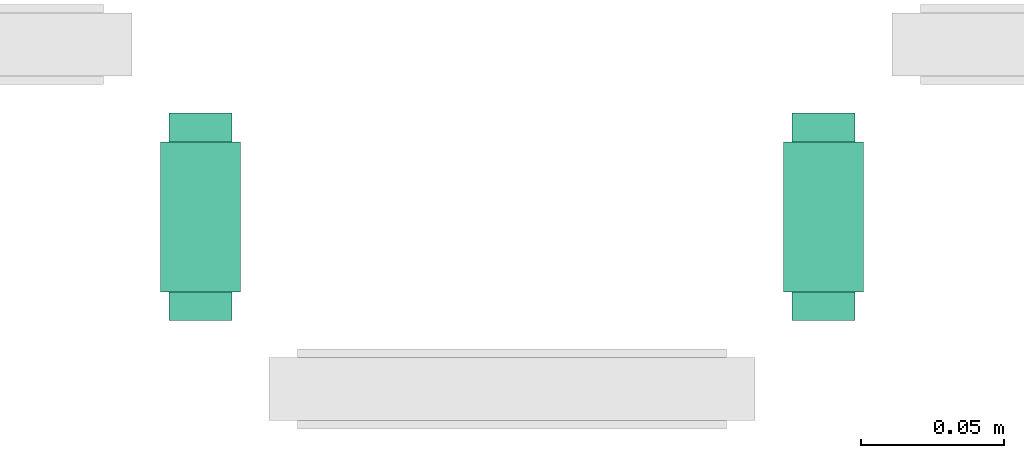
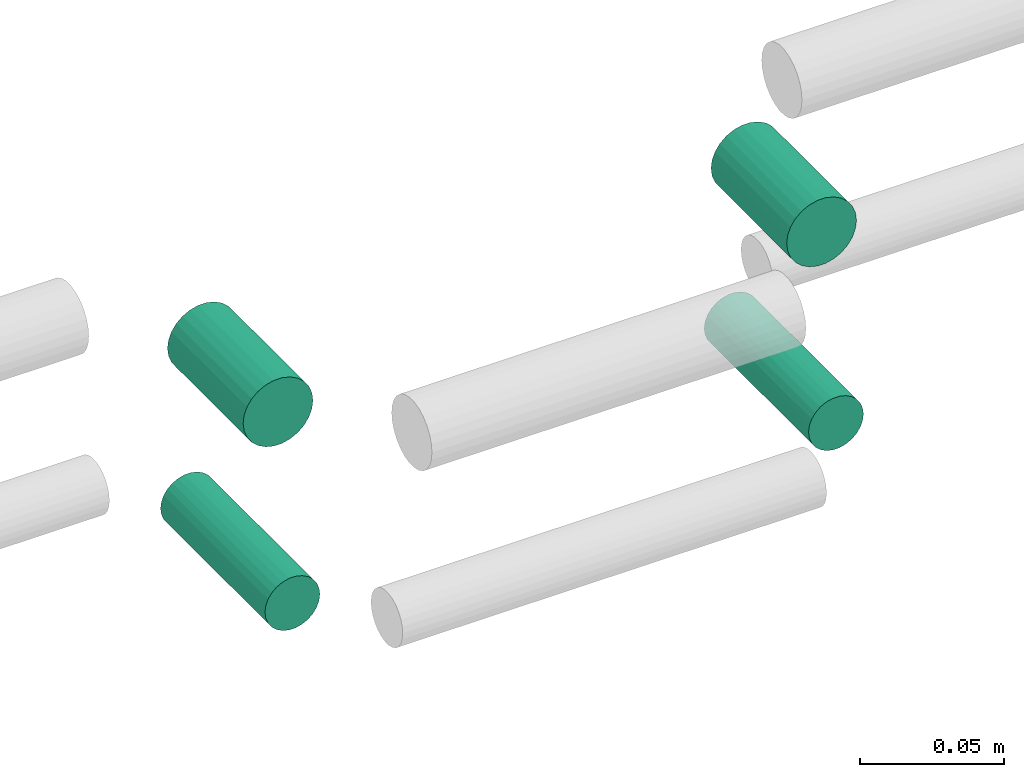
# One storey, part 285 of 331: 4 flow segments.
"""IFC2X3 building model written with IfcOpenShell, lengths in millimetres."""

from ifc_helpers import new_model, entity, si_unit, converted_unit, derived_unit, direction, frame, frame_2d, origin, origin_2d_with_axis, place, context, subcontext, project, spatial, circle, extrude, type_object, element, save


model = new_model("IFC2X3")

# Units and contexts
model_context = context("Model", 3, precision=0.01, world=origin(), true_north=direction((6.12303176911189e-17, 1.0)))
body_context = subcontext(model_context, "Body", "Model", "MODEL_VIEW")
ifc_project = project(units=[si_unit("LENGTHUNIT", "METRE", prefix="MILLI"), si_unit("AREAUNIT", "SQUARE_METRE"), si_unit("VOLUMEUNIT", "CUBIC_METRE"), converted_unit("PLANEANGLEUNIT", "DEGREE", entity("IfcRatioMeasure", 0.0174532925199433), si_unit("PLANEANGLEUNIT", "RADIAN"), dimensions=[0, 0, 0, 0, 0, 0, 0]), si_unit("MASSUNIT", "GRAM", prefix="KILO"), derived_unit("MASSDENSITYUNIT", [(si_unit("MASSUNIT", "GRAM", prefix="KILO"), 1), (si_unit("LENGTHUNIT", "METRE"), -3)]), derived_unit("MOMENTOFINERTIAUNIT", [(si_unit("LENGTHUNIT", "METRE"), 4)]), si_unit("TIMEUNIT", "SECOND"), si_unit("FREQUENCYUNIT", "HERTZ"), si_unit("THERMODYNAMICTEMPERATUREUNIT", "DEGREE_CELSIUS"), derived_unit("THERMALTRANSMITTANCEUNIT", [(si_unit("MASSUNIT", "GRAM", prefix="KILO"), 1), (si_unit("THERMODYNAMICTEMPERATUREUNIT", "KELVIN"), -1), (si_unit("TIMEUNIT", "SECOND"), -3)]), derived_unit("VOLUMETRICFLOWRATEUNIT", [(si_unit("LENGTHUNIT", "METRE"), 3), (si_unit("TIMEUNIT", "SECOND"), -1)]), derived_unit("MASSFLOWRATEUNIT", [(si_unit("MASSUNIT", "GRAM", prefix="KILO"), 1), (si_unit("TIMEUNIT", "SECOND"), -1)]), derived_unit("ROTATIONALFREQUENCYUNIT", [(si_unit("TIMEUNIT", "SECOND"), -1)]), si_unit("ELECTRICCURRENTUNIT", "AMPERE"), si_unit("ELECTRICVOLTAGEUNIT", "VOLT"), si_unit("POWERUNIT", "WATT"), si_unit("FORCEUNIT", "NEWTON", prefix="KILO"), si_unit("ILLUMINANCEUNIT", "LUX"), si_unit("LUMINOUSFLUXUNIT", "LUMEN"), si_unit("LUMINOUSINTENSITYUNIT", "CANDELA"), derived_unit("USERDEFINED", [(si_unit("MASSUNIT", "GRAM", prefix="KILO"), -1), (si_unit("LENGTHUNIT", "METRE"), -2), (si_unit("TIMEUNIT", "SECOND"), 3), (si_unit("LUMINOUSFLUXUNIT", "LUMEN"), 1)]), derived_unit("LINEARVELOCITYUNIT", [(si_unit("LENGTHUNIT", "METRE"), 1), (si_unit("TIMEUNIT", "SECOND"), -1)]), si_unit("PRESSUREUNIT", "PASCAL"), derived_unit("USERDEFINED", [(si_unit("LENGTHUNIT", "METRE"), -2), (si_unit("MASSUNIT", "GRAM", prefix="KILO"), 1), (si_unit("TIMEUNIT", "SECOND"), -2)]), derived_unit("LINEARFORCEUNIT", [(si_unit("MASSUNIT", "GRAM", prefix="KILO"), 1), (si_unit("LENGTHUNIT", "METRE"), 1), (si_unit("TIMEUNIT", "SECOND"), -2), (si_unit("LENGTHUNIT", "METRE"), -1)]), derived_unit("PLANARFORCEUNIT", [(si_unit("MASSUNIT", "GRAM", prefix="KILO"), 1), (si_unit("LENGTHUNIT", "METRE"), 1), (si_unit("TIMEUNIT", "SECOND"), -2), (si_unit("LENGTHUNIT", "METRE"), -2)])], contexts=[model_context])

# Site, building, storey
site_placement = place(None, frame((0.0, -0.00077364408347762, 0.0)))
site = spatial("IfcSite", under=ifc_project, at=site_placement, CompositionType="ELEMENT")
building_placement = place(site_placement, origin())
building = spatial("IfcBuilding", under=site, at=building_placement, CompositionType="ELEMENT")
storey_placement = place(building_placement, origin())
storey = spatial("IfcBuildingStorey", under=building, at=storey_placement, CompositionType="ELEMENT", Elevation=0.0)

# Flow segments
pipe_segment_type = type_object("IfcPipeSegmentType", PredefinedType="NOTDEFINED")
flow_segment_1_placement = place(building_placement, frame((54614.6101468952, 8109.00006103516, 2759.40472776402)))
element("IfcFlowSegment", 1, at=flow_segment_1_placement, inside=storey, type_object=pipe_segment_type, context=body_context, shape_type="SweptSolid", body=[
    extrude(circle(Radius=14.0, at=origin_2d_with_axis()), frame((15.59527223593, 0.0, 15.595272235916), z_axis=(0.0, 1.0, 0.0), x_axis=(1.0, 0.0, 0.0)), (0.0, 0.0, 1.0), 52.5162006573434),
])
flow_segment_2_placement = place(building_placement, frame((54396.6642564726, 8109.00006103515, 2759.40472776401)))
element("IfcFlowSegment", 2, at=flow_segment_2_placement, inside=storey, type_object=pipe_segment_type, context=body_context, shape_type="SweptSolid", body=[
    extrude(circle(Radius=14.0, at=origin_2d_with_axis()), frame((15.59527223593, 0.0, 15.595272235916), z_axis=(0.0, 1.0, 0.0), x_axis=(1.0, 0.0, 0.0)), (0.0, 0.0, 1.0), 52.5162006573704),
])
flow_segment_3_placement = place(building_placement, frame((54617.6101468953, 8099.00006103516, 2687.40472776402)))
element("IfcFlowSegment", 3, at=flow_segment_3_placement, inside=storey, type_object=pipe_segment_type, context=body_context, shape_type="SweptSolid", body=[
    extrude(circle(Radius=11.0, at=frame_2d((0.0, -2.14225222833041e-25), x_axis=(1.0, 0.0))), frame((12.5952722359134, 0.0, 12.5952722359161), z_axis=(0.0, 1.0, 0.0), x_axis=(1.0, 0.0, 0.0)), (0.0, 0.0, 1.0), 72.516200657498),
])
flow_segment_4_placement = place(building_placement, frame((54399.6642564726, 8099.00006103514, 2687.40472776402)))
element("IfcFlowSegment", 4, at=flow_segment_4_placement, inside=storey, type_object=pipe_segment_type, context=body_context, shape_type="SweptSolid", body=[
    extrude(circle(Radius=11.0, at=frame_2d((0.0, -1.0711261141653e-24), x_axis=(1.0, 0.0))), frame((12.5952722359481, 0.0, 12.5952722359161), z_axis=(0.0, 1.0, 0.0), x_axis=(1.0, 0.0, 0.0)), (0.0, 0.0, 1.0), 72.5162006575175),
])

save(model, "model.ifc")
